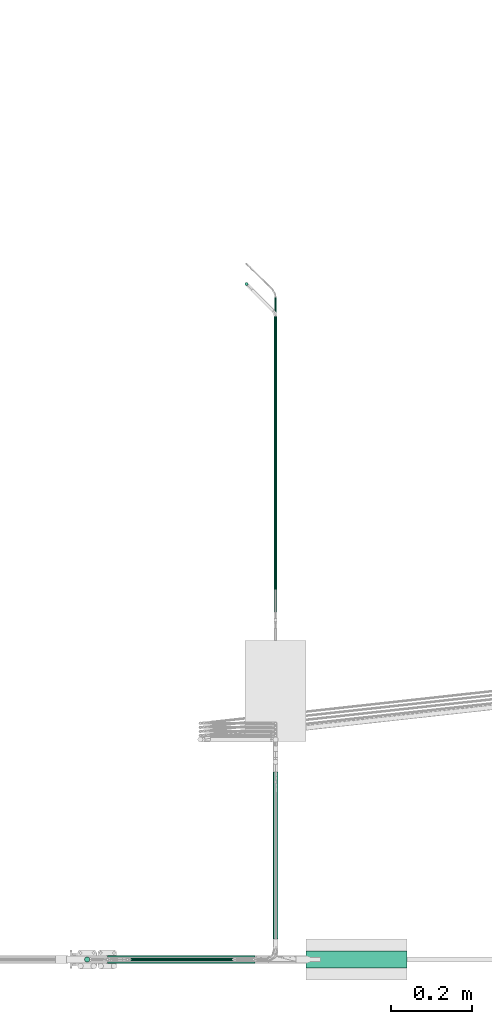
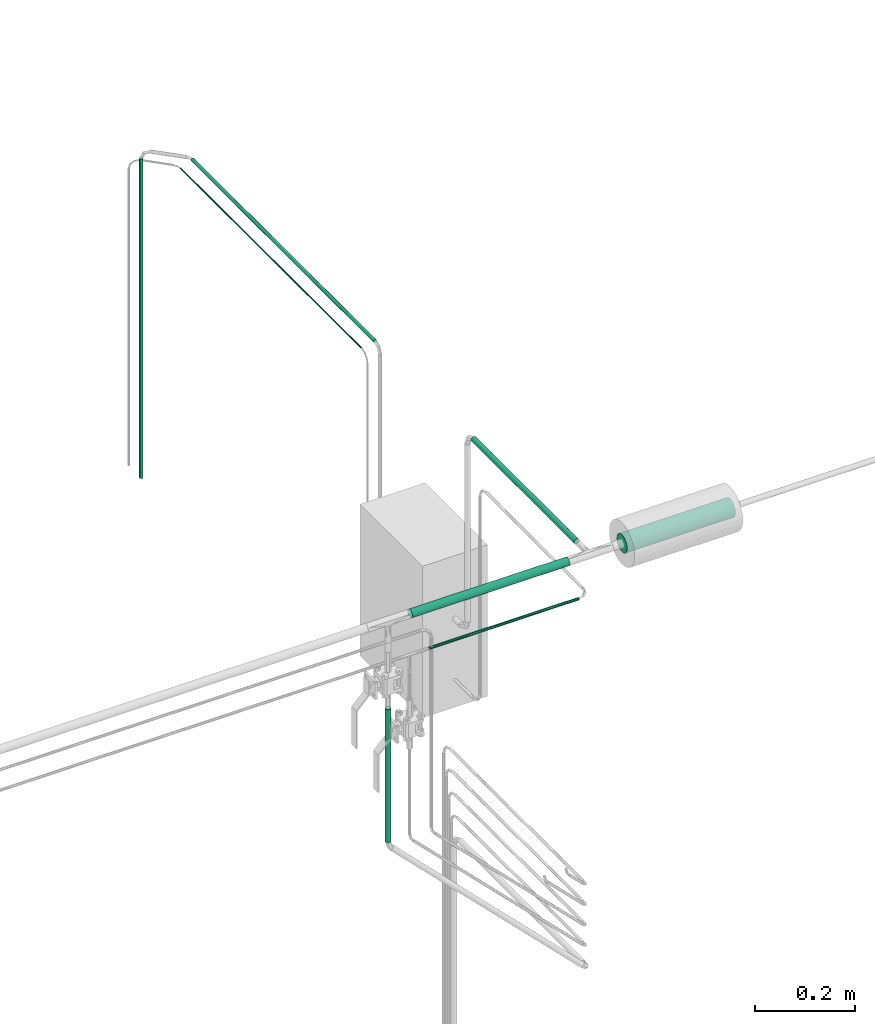
# One storey, part 14 of 45: 8 flow segments.
"""IFC2X3 building model written with IfcOpenShell, lengths in millimetres."""

from ifc_helpers import new_model, entity, si_unit, converted_unit, derived_unit, direction, frame, origin, origin_2d_with_axis, place, context, subcontext, project, spatial, circle, extrude, type_object, element, save


model = new_model("IFC2X3")

# Units and contexts
model_context = context("Model", 3, precision=0.01, world=origin(), true_north=direction((6.12303176911189e-17, 1.0)))
body_context = subcontext(model_context, "Body", "Model", "MODEL_VIEW")
ifc_project = project(units=[si_unit("LENGTHUNIT", "METRE", prefix="MILLI"), si_unit("AREAUNIT", "SQUARE_METRE"), si_unit("VOLUMEUNIT", "CUBIC_METRE"), converted_unit("PLANEANGLEUNIT", "DEGREE", entity("IfcRatioMeasure", 0.0174532925199433), si_unit("PLANEANGLEUNIT", "RADIAN"), dimensions=[0, 0, 0, 0, 0, 0, 0]), si_unit("MASSUNIT", "GRAM", prefix="KILO"), derived_unit("MASSDENSITYUNIT", [(si_unit("MASSUNIT", "GRAM", prefix="KILO"), 1), (si_unit("LENGTHUNIT", "METRE"), -3)]), derived_unit("MOMENTOFINERTIAUNIT", [(si_unit("LENGTHUNIT", "METRE"), 4)]), si_unit("TIMEUNIT", "SECOND"), si_unit("FREQUENCYUNIT", "HERTZ"), si_unit("THERMODYNAMICTEMPERATUREUNIT", "DEGREE_CELSIUS"), derived_unit("THERMALTRANSMITTANCEUNIT", [(si_unit("MASSUNIT", "GRAM", prefix="KILO"), 1), (si_unit("THERMODYNAMICTEMPERATUREUNIT", "KELVIN"), -1), (si_unit("TIMEUNIT", "SECOND"), -3)]), derived_unit("VOLUMETRICFLOWRATEUNIT", [(si_unit("LENGTHUNIT", "METRE"), 3), (si_unit("TIMEUNIT", "SECOND"), -1)]), derived_unit("MASSFLOWRATEUNIT", [(si_unit("MASSUNIT", "GRAM", prefix="KILO"), 1), (si_unit("TIMEUNIT", "SECOND"), -1)]), derived_unit("ROTATIONALFREQUENCYUNIT", [(si_unit("TIMEUNIT", "SECOND"), -1)]), si_unit("ELECTRICCURRENTUNIT", "AMPERE"), si_unit("ELECTRICVOLTAGEUNIT", "VOLT"), si_unit("POWERUNIT", "WATT"), si_unit("FORCEUNIT", "NEWTON", prefix="KILO"), si_unit("ILLUMINANCEUNIT", "LUX"), si_unit("LUMINOUSFLUXUNIT", "LUMEN"), si_unit("LUMINOUSINTENSITYUNIT", "CANDELA"), derived_unit("USERDEFINED", [(si_unit("MASSUNIT", "GRAM", prefix="KILO"), -1), (si_unit("LENGTHUNIT", "METRE"), -2), (si_unit("TIMEUNIT", "SECOND"), 3), (si_unit("LUMINOUSFLUXUNIT", "LUMEN"), 1)]), derived_unit("LINEARVELOCITYUNIT", [(si_unit("LENGTHUNIT", "METRE"), 1), (si_unit("TIMEUNIT", "SECOND"), -1)]), si_unit("PRESSUREUNIT", "PASCAL"), derived_unit("USERDEFINED", [(si_unit("LENGTHUNIT", "METRE"), -2), (si_unit("MASSUNIT", "GRAM", prefix="KILO"), 1), (si_unit("TIMEUNIT", "SECOND"), -2)]), derived_unit("LINEARFORCEUNIT", [(si_unit("MASSUNIT", "GRAM", prefix="KILO"), 1), (si_unit("LENGTHUNIT", "METRE"), 1), (si_unit("TIMEUNIT", "SECOND"), -2), (si_unit("LENGTHUNIT", "METRE"), -1)]), derived_unit("PLANARFORCEUNIT", [(si_unit("MASSUNIT", "GRAM", prefix="KILO"), 1), (si_unit("LENGTHUNIT", "METRE"), 1), (si_unit("TIMEUNIT", "SECOND"), -2), (si_unit("LENGTHUNIT", "METRE"), -2)])], contexts=[model_context])

# Site, building, storey
site_placement = place(None, frame((-24836.06, 8968.75, 0.0)))
site = spatial("IfcSite", under=ifc_project, at=site_placement, CompositionType="ELEMENT")
building_placement = place(site_placement, origin())
building = spatial("IfcBuilding", under=site, at=building_placement, CompositionType="ELEMENT")
storey_placement = place(building_placement, frame((0.0, 0.0, -4200.0)))
storey = spatial("IfcBuildingStorey", under=building, at=storey_placement, CompositionType="ELEMENT", Elevation=-4200.0)

# Flow segments
pipe_segment_type_1 = type_object("IfcPipeSegmentType", PredefinedType="NOTDEFINED")
flow_segment_1_placement = place(storey_placement, frame((69647.72, -8023.55, 2146.81)))
element("IfcFlowSegment", 1, at=flow_segment_1_placement, inside=storey, type_object=pipe_segment_type_1, context=body_context, shape_type="SweptSolid", body=[
    extrude(circle(Radius=1.59, at=origin_2d_with_axis()), frame((3.19, 0.0, 3.19), z_axis=(0.0, 1.0, 0.0), x_axis=(1.0, 0.0, 0.0)), (0.0, 0.0, 1.0), 722.508737042373),
])
flow_segment_2_placement = place(storey_placement, frame((69177.37, -8945.19, 1662.17)))
element("IfcFlowSegment", 2, at=flow_segment_2_placement, inside=storey, type_object=pipe_segment_type_1, context=body_context, shape_type="SweptSolid", body=[
    extrude(circle(Radius=6.35, at=origin_2d_with_axis()), frame((7.95, 7.95, 0.0)), (0.0, 0.0, 1.0), 325.070738331686),
])
flow_segment_3_placement = place(storey_placement, frame((69236.11, -8948.36, 2188.88)))
element("IfcFlowSegment", 3, at=flow_segment_3_placement, inside=storey, type_object=pipe_segment_type_1, context=body_context, shape_type="SweptSolid", body=[
    extrude(circle(Radius=9.525, at=origin_2d_with_axis()), frame((0.0, 11.12, 11.12), z_axis=(1.0, 0.0, 0.0), x_axis=(0.0, 1.0, 0.0)), (0.0, 0.0, 1.0), 363.993890337554),
])
flow_segment_4_placement = place(storey_placement, frame((69642.96, -8886.44, 2192.05)))
element("IfcFlowSegment", 4, at=flow_segment_4_placement, inside=storey, type_object=pipe_segment_type_1, context=body_context, shape_type="SweptSolid", body=[
    extrude(circle(Radius=6.35, at=origin_2d_with_axis()), frame((7.95, 0.0, 7.95), z_axis=(0.0, 1.0, 0.0), x_axis=(-1.0, 0.0, 0.0)), (0.0, 0.0, 1.0), 412.093545192868),
])
flow_segment_5_placement = place(storey_placement, frame((69279.81, -8942.01, 2095.23)))
element("IfcFlowSegment", 5, at=flow_segment_5_placement, inside=storey, type_object=pipe_segment_type_1, context=body_context, shape_type="SweptSolid", body=[
    extrude(circle(Radius=3.175, at=origin_2d_with_axis()), frame((0.0, 4.77, 4.77), z_axis=(1.0, 0.0, 0.0), x_axis=(0.0, -1.0, 0.0)), (0.0, 0.0, 1.0), 345.693890337549),
])
pipe_segment_type_2 = type_object("IfcPipeSegmentType", PredefinedType="NOTDEFINED")
flow_segment_6_placement = place(storey_placement, frame((69573.2, -7274.0, 1400.0)))
element("IfcFlowSegment", 6, at=flow_segment_6_placement, inside=storey, type_object=pipe_segment_type_2, context=body_context, shape_type="SweptSolid", body=[
    extrude(circle(Radius=4.0, at=origin_2d_with_axis()), frame((5.6, 5.6, 0.0), z_axis=(0.0, 0.0, 1.0), x_axis=(-1.0, 0.0, 0.0)), (0.0, 0.0, 1.0), 780.0),
])
flow_segment_7_placement = place(storey_placement, frame((69645.31, -8078.95, 2194.4)))
element("IfcFlowSegment", 7, at=flow_segment_7_placement, inside=storey, type_object=pipe_segment_type_2, context=body_context, shape_type="SweptSolid", body=[
    extrude(circle(Radius=4.0, at=origin_2d_with_axis()), frame((5.6, 0.0, 5.6), z_axis=(0.0, 1.0, 0.0), x_axis=(-1.0, 0.0, 0.0)), (0.0, 0.0, 1.0), 730.145490279176),
])
pipe_segment_type_3 = type_object("IfcPipeSegmentType", PredefinedType="NOTDEFINED")
flow_segment_8_placement = place(storey_placement, frame((69725.89, -8959.99, 2177.25)))
element("IfcFlowSegment", 8, at=flow_segment_8_placement, inside=storey, type_object=pipe_segment_type_3, context=body_context, shape_type="SweptSolid", body=[
    extrude(circle(Radius=21.15, at=origin_2d_with_axis()), frame((0.0, 22.75, 22.75), z_axis=(1.0, 0.0, 0.0), x_axis=(0.0, -1.0, 0.0)), (0.0, 0.0, 1.0), 250.02068283133),
])

save(model, "model.ifc")
